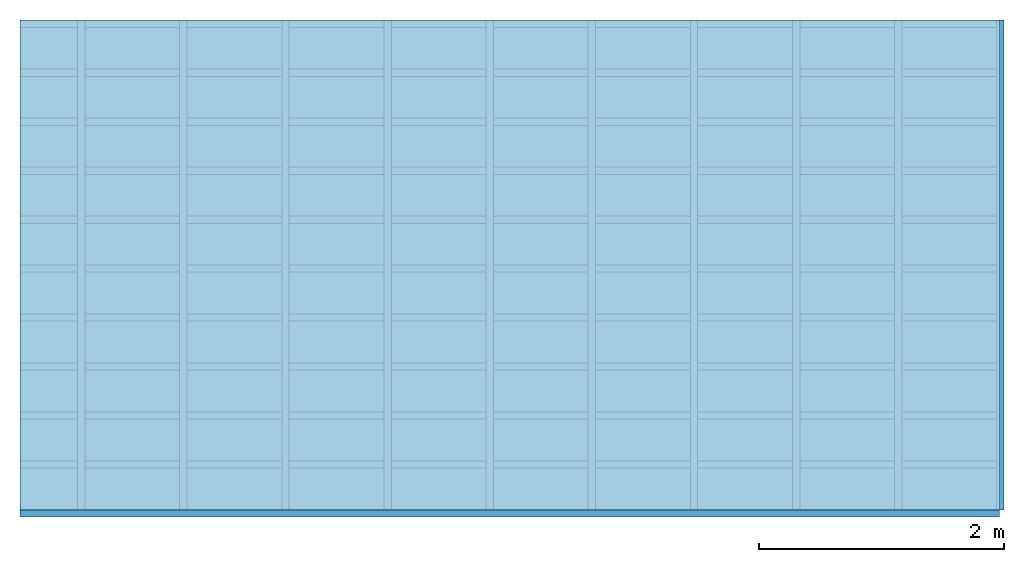
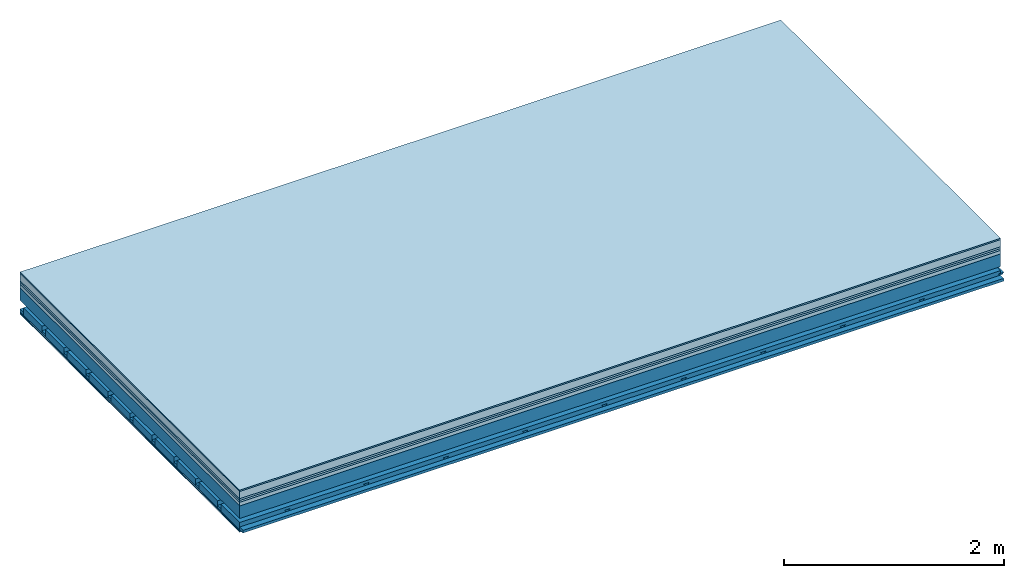
# One storey: 8 plates, 4 members, 1 element without a shape of its own.
"""IFC4 building model written with IfcOpenShell, lengths in metres."""

from ifc_helpers import new_model, si_unit, derived_unit, direction, frame, frame_2d, origin, origin_with_axes, place, context, project, spatial, polyline, rectangle, outline, extrude, material, layer, layer_set, type_object, element, aggregate, save


model = new_model("IFC4")

# Units and contexts
plan_context = context("Plan", 3, precision=1e-05, world=origin(), true_north=direction((0.0, 1.0)))
model_context = context("Model", 3, precision=1e-05, world=origin(), true_north=direction((0.0, 1.0)))
ifc_project = project(units=[si_unit("LENGTHUNIT", "METRE"), derived_unit("SOUNDPRESSUREUNIT", [(si_unit("PRESSUREUNIT", "PASCAL", prefix="MICRO"), 0)]), si_unit("ENERGYUNIT", "JOULE", prefix="MEGA"), si_unit("MASSUNIT", "GRAM", prefix="KILO"), derived_unit("THERMALTRANSMITTANCEUNIT", [(si_unit("POWERUNIT", "WATT"), 1), (si_unit("AREAUNIT", "SQUARE_METRE"), -1), (si_unit("THERMODYNAMICTEMPERATUREUNIT", "KELVIN"), -1)]), derived_unit("AREADENSITYUNIT", [(si_unit("MASSUNIT", "GRAM", prefix="KILO"), 1), (si_unit("AREAUNIT", "SQUARE_METRE"), -1)]), derived_unit("USERDEFINED", [(si_unit("ENERGYUNIT", "JOULE", prefix="MEGA"), 1), (si_unit("AREAUNIT", "SQUARE_METRE"), -1)])], contexts=[plan_context, model_context])

# Site, building, storey
site = spatial("IfcSite", under=ifc_project)
building_placement = place(None, origin())
building = spatial("IfcBuilding", under=site, at=building_placement)
storey_placement = place(building_placement, origin())
storey = spatial("IfcBuildingStorey", under=building, at=storey_placement)

# Slab, members, plates
ifc_material_1 = material(Category="11.013")
ifc_layer_1 = layer(ifc_material_1, 0.015, Name="Flooring")
ifc_material_2 = material(Name="Cement screed", Category="04.006")
ifc_layer_2 = layer(ifc_material_2, 0.08, Name="On-material")
ifc_material_3 = material(Name="Wood fiber generic product", Category="10.009")
ifc_layer_3 = layer(ifc_material_3, 0.02, Name="Impact sound insulation")
ifc_material_4 = material(Category="10.004")
ifc_layer_4 = layer(ifc_material_4, 0.02, Name="Additional insulation")
ifc_material_5 = material(Name="Garden plates", Category="02.007")
ifc_layer_5 = layer(ifc_material_5, 0.04, Name="on Supporting structure")
ifc_material_6 = material(Name="no composite action")
ifc_layer_6 = layer(ifc_material_6, 0.0, Name="Bond")
ifc_layer_7 = layer(None, 0.14, Name="Supporting structure")
ifc_layer_8 = layer(ifc_material_6, 0.0, Name="Bond")
ifc_layer_9 = layer(None, 0.095, Name="Coupling")
ifc_layer_10 = layer(None, 0.03, Name="Battens / profiles")
ifc_material_7 = material(Name="Plasterboard type A", Category="03.008")
ifc_layer_11 = layer(ifc_material_7, 0.0125, Name="Ceiling covering 1st layer")
ifc_layer_12 = layer(ifc_material_7, 0.0125, Name="Ceiling covering layer 2")
ifc_material_8 = material(Category="04.001")
ifc_layer_13 = layer(ifc_material_8, 0.003, Name="Surface / treatment")
ifc_layer_set = layer_set([ifc_layer_1, ifc_layer_2, ifc_layer_3, ifc_layer_4, ifc_layer_5, ifc_layer_6, ifc_layer_7, ifc_layer_8, ifc_layer_9, ifc_layer_10, ifc_layer_11, ifc_layer_12, ifc_layer_13])
slab_type = type_object("IfcSlabType", Name="A2169", PredefinedType="NOTDEFINED", material=ifc_layer_set)
slab_placement = place(None, frame((0.0, 0.0, 0.0), z_axis=(0.0, 0.0, -1.0), x_axis=(1.0, 0.0, 0.0)))
slab = element("IfcSlab", 1, at=slab_placement, inside=storey, type_object=slab_type, material=ifc_layer_set, Name="Slab #1")
ifc_material_9 = material(Name="Solid timber panel")
member_1_placement = place(slab_placement, origin())
member_1 = element("IfcMember", 2, at=member_1_placement, material=ifc_material_9, Name="Supporting structure", context=plan_context, shape_type="SweptSolid", body=[
    extrude(rectangle(XDim=1.0, YDim=0.14, at=frame_2d((0.5, 0.07), x_axis=(1.0, 0.0))), frame((0.0, 4.0, 0.175), z_axis=(0.0, -1.0, 0.0), x_axis=(1.0, 0.0, 0.0)), (0.0, 0.0, 1.0), 4.0),
    extrude(rectangle(XDim=1.0, YDim=0.14, at=frame_2d((0.5, 0.07), x_axis=(1.0, 0.0))), frame((1.0, 4.0, 0.175), z_axis=(0.0, -1.0, 0.0), x_axis=(1.0, 0.0, 0.0)), (0.0, 0.0, 1.0), 4.0),
    extrude(rectangle(XDim=1.0, YDim=0.14, at=frame_2d((0.5, 0.07), x_axis=(1.0, 0.0))), frame((2.0, 4.0, 0.175), z_axis=(0.0, -1.0, 0.0), x_axis=(1.0, 0.0, 0.0)), (0.0, 0.0, 1.0), 4.0),
    extrude(rectangle(XDim=1.0, YDim=0.14, at=frame_2d((0.5, 0.07), x_axis=(1.0, 0.0))), frame((3.0, 4.0, 0.175), z_axis=(0.0, -1.0, 0.0), x_axis=(1.0, 0.0, 0.0)), (0.0, 0.0, 1.0), 4.0),
    extrude(rectangle(XDim=1.0, YDim=0.14, at=frame_2d((0.5, 0.07), x_axis=(1.0, 0.0))), frame((4.0, 4.0, 0.175), z_axis=(0.0, -1.0, 0.0), x_axis=(1.0, 0.0, 0.0)), (0.0, 0.0, 1.0), 4.0),
    extrude(rectangle(XDim=1.0, YDim=0.14, at=frame_2d((0.5, 0.07), x_axis=(1.0, 0.0))), frame((5.0, 4.0, 0.175), z_axis=(0.0, -1.0, 0.0), x_axis=(1.0, 0.0, 0.0)), (0.0, 0.0, 1.0), 4.0),
    extrude(rectangle(XDim=1.0, YDim=0.14, at=frame_2d((0.5, 0.07), x_axis=(1.0, 0.0))), frame((6.0, 4.0, 0.175), z_axis=(0.0, -1.0, 0.0), x_axis=(1.0, 0.0, 0.0)), (0.0, 0.0, 1.0), 4.0),
    extrude(rectangle(XDim=1.0, YDim=0.14, at=frame_2d((0.5, 0.07), x_axis=(1.0, 0.0))), frame((7.0, 4.0, 0.175), z_axis=(0.0, -1.0, 0.0), x_axis=(1.0, 0.0, 0.0)), (0.0, 0.0, 1.0), 4.0),
])
ifc_material_10 = material()
member_2_placement = place(slab_placement, origin())
member_2 = element("IfcMember", 3, at=member_2_placement, material=ifc_material_10, Name="Coupling", context=plan_context, shape_type="SweptSolid", body=[
    extrude(outline(polyline([(0.0, 0.0), (0.06, 0.0), (0.04, 0.02), (0.02, 0.02), (0.0, 0.0)])), frame((0.47, 4.0, 0.39), z_axis=(0.0, -1.0, 0.0), x_axis=(1.0, 0.0, 0.0)), (0.0, 0.0, 1.0), 4.0),
    extrude(outline(polyline([(0.0, 0.0), (0.06, 0.0), (0.04, 0.02), (0.02, 0.02), (0.0, 0.0)])), frame((1.304, 4.0, 0.39), z_axis=(0.0, -1.0, 0.0), x_axis=(1.0, 0.0, 0.0)), (0.0, 0.0, 1.0), 4.0),
    extrude(outline(polyline([(0.0, 0.0), (0.06, 0.0), (0.04, 0.02), (0.02, 0.02), (0.0, 0.0)])), frame((2.138, 4.0, 0.39), z_axis=(0.0, -1.0, 0.0), x_axis=(1.0, 0.0, 0.0)), (0.0, 0.0, 1.0), 4.0),
    extrude(outline(polyline([(0.0, 0.0), (0.06, 0.0), (0.04, 0.02), (0.02, 0.02), (0.0, 0.0)])), frame((2.972, 4.0, 0.39), z_axis=(0.0, -1.0, 0.0), x_axis=(1.0, 0.0, 0.0)), (0.0, 0.0, 1.0), 4.0),
    extrude(outline(polyline([(0.0, 0.0), (0.06, 0.0), (0.04, 0.02), (0.02, 0.02), (0.0, 0.0)])), frame((3.806, 4.0, 0.39), z_axis=(0.0, -1.0, 0.0), x_axis=(1.0, 0.0, 0.0)), (0.0, 0.0, 1.0), 4.0),
    extrude(outline(polyline([(0.0, 0.0), (0.06, 0.0), (0.04, 0.02), (0.02, 0.02), (0.0, 0.0)])), frame((4.64, 4.0, 0.39), z_axis=(0.0, -1.0, 0.0), x_axis=(1.0, 0.0, 0.0)), (0.0, 0.0, 1.0), 4.0),
    extrude(outline(polyline([(0.0, 0.0), (0.06, 0.0), (0.04, 0.02), (0.02, 0.02), (0.0, 0.0)])), frame((5.474, 4.0, 0.39), z_axis=(0.0, -1.0, 0.0), x_axis=(1.0, 0.0, 0.0)), (0.0, 0.0, 1.0), 4.0),
    extrude(outline(polyline([(0.0, 0.0), (0.06, 0.0), (0.04, 0.02), (0.02, 0.02), (0.0, 0.0)])), frame((6.308, 4.0, 0.39), z_axis=(0.0, -1.0, 0.0), x_axis=(1.0, 0.0, 0.0)), (0.0, 0.0, 1.0), 4.0),
    extrude(outline(polyline([(0.0, 0.0), (0.06, 0.0), (0.04, 0.02), (0.02, 0.02), (0.0, 0.0)])), frame((7.142, 4.0, 0.39), z_axis=(0.0, -1.0, 0.0), x_axis=(1.0, 0.0, 0.0)), (0.0, 0.0, 1.0), 4.0),
    extrude(outline(polyline([(0.0, 0.0), (0.06, 0.0), (0.04, 0.02), (0.02, 0.02), (0.0, 0.0)])), frame((7.976, 4.0, 0.39), z_axis=(0.0, -1.0, 0.0), x_axis=(1.0, 0.0, 0.0)), (0.0, 0.0, 1.0), 4.0),
])
member_3_placement = place(slab_placement, origin())
member_3 = element("IfcMember", 4, at=member_3_placement, material=ifc_material_10, Name="Battens / profiles", context=plan_context, shape_type="SweptSolid", body=[
    extrude(rectangle(XDim=0.06, YDim=0.03, at=frame_2d((0.03, 0.015), x_axis=(1.0, 0.0))), frame((0.0, 0.0, 0.41), z_axis=(1.0, 0.0, 0.0), x_axis=(0.0, 1.0, 0.0)), (0.0, 0.0, 1.0), 8.0),
    extrude(rectangle(XDim=0.06, YDim=0.03, at=frame_2d((0.03, 0.015), x_axis=(1.0, 0.0))), frame((0.0, 0.4, 0.41), z_axis=(1.0, 0.0, 0.0), x_axis=(0.0, 1.0, 0.0)), (0.0, 0.0, 1.0), 8.0),
    extrude(rectangle(XDim=0.06, YDim=0.03, at=frame_2d((0.03, 0.015), x_axis=(1.0, 0.0))), frame((0.0, 0.8, 0.41), z_axis=(1.0, 0.0, 0.0), x_axis=(0.0, 1.0, 0.0)), (0.0, 0.0, 1.0), 8.0),
    extrude(rectangle(XDim=0.06, YDim=0.03, at=frame_2d((0.03, 0.015), x_axis=(1.0, 0.0))), frame((0.0, 1.2, 0.41), z_axis=(1.0, 0.0, 0.0), x_axis=(0.0, 1.0, 0.0)), (0.0, 0.0, 1.0), 8.0),
    extrude(rectangle(XDim=0.06, YDim=0.03, at=frame_2d((0.03, 0.015), x_axis=(1.0, 0.0))), frame((0.0, 1.6, 0.41), z_axis=(1.0, 0.0, 0.0), x_axis=(0.0, 1.0, 0.0)), (0.0, 0.0, 1.0), 8.0),
    extrude(rectangle(XDim=0.06, YDim=0.03, at=frame_2d((0.03, 0.015), x_axis=(1.0, 0.0))), frame((0.0, 2.0, 0.41), z_axis=(1.0, 0.0, 0.0), x_axis=(0.0, 1.0, 0.0)), (0.0, 0.0, 1.0), 8.0),
    extrude(rectangle(XDim=0.06, YDim=0.03, at=frame_2d((0.03, 0.015), x_axis=(1.0, 0.0))), frame((0.0, 2.4, 0.41), z_axis=(1.0, 0.0, 0.0), x_axis=(0.0, 1.0, 0.0)), (0.0, 0.0, 1.0), 8.0),
    extrude(rectangle(XDim=0.06, YDim=0.03, at=frame_2d((0.03, 0.015), x_axis=(1.0, 0.0))), frame((0.0, 2.8, 0.41), z_axis=(1.0, 0.0, 0.0), x_axis=(0.0, 1.0, 0.0)), (0.0, 0.0, 1.0), 8.0),
    extrude(rectangle(XDim=0.06, YDim=0.03, at=frame_2d((0.03, 0.015), x_axis=(1.0, 0.0))), frame((0.0, 3.2, 0.41), z_axis=(1.0, 0.0, 0.0), x_axis=(0.0, 1.0, 0.0)), (0.0, 0.0, 1.0), 8.0),
    extrude(rectangle(XDim=0.06, YDim=0.03, at=frame_2d((0.03, 0.015), x_axis=(1.0, 0.0))), frame((0.0, 3.6, 0.41), z_axis=(1.0, 0.0, 0.0), x_axis=(0.0, 1.0, 0.0)), (0.0, 0.0, 1.0), 8.0),
    extrude(rectangle(XDim=0.06, YDim=0.03, at=frame_2d((0.03, 0.015), x_axis=(1.0, 0.0))), frame((0.0, 4.0, 0.41), z_axis=(1.0, 0.0, 0.0), x_axis=(0.0, 1.0, 0.0)), (0.0, 0.0, 1.0), 8.0),
])
ifc_material_11 = material()
member_4_placement = place(slab_placement, origin())
member_4 = element("IfcMember", 5, at=member_4_placement, material=ifc_material_11, Name="Cavity", context=plan_context, shape_type="SweptSolid", body=[
    extrude(rectangle(XDim=0.34, YDim=0.08, at=frame_2d((0.17, 0.04), x_axis=(1.0, 0.0))), frame((0.0, 0.06, 0.36), z_axis=(1.0, 0.0, 0.0), x_axis=(0.0, 1.0, 0.0)), (0.0, 0.0, 1.0), 8.0),
    extrude(rectangle(XDim=0.34, YDim=0.08, at=frame_2d((0.17, 0.04), x_axis=(1.0, 0.0))), frame((0.0, 0.46, 0.36), z_axis=(1.0, 0.0, 0.0), x_axis=(0.0, 1.0, 0.0)), (0.0, 0.0, 1.0), 8.0),
    extrude(rectangle(XDim=0.34, YDim=0.08, at=frame_2d((0.17, 0.04), x_axis=(1.0, 0.0))), frame((0.0, 0.86, 0.36), z_axis=(1.0, 0.0, 0.0), x_axis=(0.0, 1.0, 0.0)), (0.0, 0.0, 1.0), 8.0),
    extrude(rectangle(XDim=0.34, YDim=0.08, at=frame_2d((0.17, 0.04), x_axis=(1.0, 0.0))), frame((0.0, 1.26, 0.36), z_axis=(1.0, 0.0, 0.0), x_axis=(0.0, 1.0, 0.0)), (0.0, 0.0, 1.0), 8.0),
    extrude(rectangle(XDim=0.34, YDim=0.08, at=frame_2d((0.17, 0.04), x_axis=(1.0, 0.0))), frame((0.0, 1.66, 0.36), z_axis=(1.0, 0.0, 0.0), x_axis=(0.0, 1.0, 0.0)), (0.0, 0.0, 1.0), 8.0),
    extrude(rectangle(XDim=0.34, YDim=0.08, at=frame_2d((0.17, 0.04), x_axis=(1.0, 0.0))), frame((0.0, 2.06, 0.36), z_axis=(1.0, 0.0, 0.0), x_axis=(0.0, 1.0, 0.0)), (0.0, 0.0, 1.0), 8.0),
    extrude(rectangle(XDim=0.34, YDim=0.08, at=frame_2d((0.17, 0.04), x_axis=(1.0, 0.0))), frame((0.0, 2.46, 0.36), z_axis=(1.0, 0.0, 0.0), x_axis=(0.0, 1.0, 0.0)), (0.0, 0.0, 1.0), 8.0),
    extrude(rectangle(XDim=0.34, YDim=0.08, at=frame_2d((0.17, 0.04), x_axis=(1.0, 0.0))), frame((0.0, 2.86, 0.36), z_axis=(1.0, 0.0, 0.0), x_axis=(0.0, 1.0, 0.0)), (0.0, 0.0, 1.0), 8.0),
    extrude(rectangle(XDim=0.34, YDim=0.08, at=frame_2d((0.17, 0.04), x_axis=(1.0, 0.0))), frame((0.0, 3.26, 0.36), z_axis=(1.0, 0.0, 0.0), x_axis=(0.0, 1.0, 0.0)), (0.0, 0.0, 1.0), 8.0),
    extrude(rectangle(XDim=0.34, YDim=0.08, at=frame_2d((0.17, 0.04), x_axis=(1.0, 0.0))), frame((0.0, 3.66, 0.36), z_axis=(1.0, 0.0, 0.0), x_axis=(0.0, 1.0, 0.0)), (0.0, 0.0, 1.0), 8.0),
])
plate_1_placement = place(slab_placement, origin())
plate_1 = element("IfcPlate", 6, at=plate_1_placement, material=ifc_material_1, Name="Flooring", context=plan_context, shape_type="SweptSolid", body=[
    extrude(rectangle(XDim=8.0, YDim=4.0, at=frame_2d((4.0, 2.0), x_axis=(1.0, 0.0))), origin_with_axes(), (0.0, 0.0, 1.0), 0.015),
])
plate_2_placement = place(slab_placement, origin())
plate_2 = element("IfcPlate", 7, at=plate_2_placement, material=ifc_material_2, Name="On-material", context=plan_context, shape_type="SweptSolid", body=[
    extrude(rectangle(XDim=8.0, YDim=4.0, at=frame_2d((4.0, 2.0), x_axis=(1.0, 0.0))), frame((0.0, 0.0, 0.015), z_axis=(0.0, 0.0, 1.0), x_axis=(1.0, 0.0, 0.0)), (0.0, 0.0, 1.0), 0.08),
])
plate_3_placement = place(slab_placement, origin())
plate_3 = element("IfcPlate", 8, at=plate_3_placement, material=ifc_material_3, Name="Impact sound insulation", context=plan_context, shape_type="SweptSolid", body=[
    extrude(rectangle(XDim=8.0, YDim=4.0, at=frame_2d((4.0, 2.0), x_axis=(1.0, 0.0))), frame((0.0, 0.0, 0.095), z_axis=(0.0, 0.0, 1.0), x_axis=(1.0, 0.0, 0.0)), (0.0, 0.0, 1.0), 0.02),
])
plate_4_placement = place(slab_placement, origin())
plate_4 = element("IfcPlate", 9, at=plate_4_placement, material=ifc_material_4, Name="Additional insulation", context=plan_context, shape_type="SweptSolid", body=[
    extrude(rectangle(XDim=8.0, YDim=4.0, at=frame_2d((4.0, 2.0), x_axis=(1.0, 0.0))), frame((0.0, 0.0, 0.115), z_axis=(0.0, 0.0, 1.0), x_axis=(1.0, 0.0, 0.0)), (0.0, 0.0, 1.0), 0.02),
])
plate_5_placement = place(slab_placement, origin())
plate_5 = element("IfcPlate", 10, at=plate_5_placement, material=ifc_material_5, Name="on Supporting structure", context=plan_context, shape_type="SweptSolid", body=[
    extrude(rectangle(XDim=8.0, YDim=4.0, at=frame_2d((4.0, 2.0), x_axis=(1.0, 0.0))), frame((0.0, 0.0, 0.135), z_axis=(0.0, 0.0, 1.0), x_axis=(1.0, 0.0, 0.0)), (0.0, 0.0, 1.0), 0.04),
])
plate_6_placement = place(slab_placement, origin())
plate_6 = element("IfcPlate", 11, at=plate_6_placement, material=ifc_material_7, Name="Ceiling covering 1st layer", context=plan_context, shape_type="SweptSolid", body=[
    extrude(rectangle(XDim=8.0, YDim=4.0, at=frame_2d((4.0, 2.0), x_axis=(1.0, 0.0))), frame((0.0, 0.0, 0.44), z_axis=(0.0, 0.0, 1.0), x_axis=(1.0, 0.0, 0.0)), (0.0, 0.0, 1.0), 0.0125),
])
plate_7_placement = place(slab_placement, origin())
plate_7 = element("IfcPlate", 12, at=plate_7_placement, material=ifc_material_7, Name="Ceiling covering layer 2", context=plan_context, shape_type="SweptSolid", body=[
    extrude(rectangle(XDim=8.0, YDim=4.0, at=frame_2d((4.0, 2.0), x_axis=(1.0, 0.0))), frame((0.0, 0.0, 0.4525), z_axis=(0.0, 0.0, 1.0), x_axis=(1.0, 0.0, 0.0)), (0.0, 0.0, 1.0), 0.0125),
])
plate_8_placement = place(slab_placement, origin())
plate_8 = element("IfcPlate", 13, at=plate_8_placement, material=ifc_material_8, Name="Surface / treatment", context=plan_context, shape_type="SweptSolid", body=[
    extrude(rectangle(XDim=8.0, YDim=4.0, at=frame_2d((4.0, 2.0), x_axis=(1.0, 0.0))), frame((0.0, 0.0, 0.465), z_axis=(0.0, 0.0, 1.0), x_axis=(1.0, 0.0, 0.0)), (0.0, 0.0, 1.0), 0.003),
])
aggregate(slab, [plate_1, plate_2, plate_3, plate_4, plate_5, member_1, member_2, member_3, member_4, plate_6, plate_7, plate_8])

save(model, "model.ifc")
